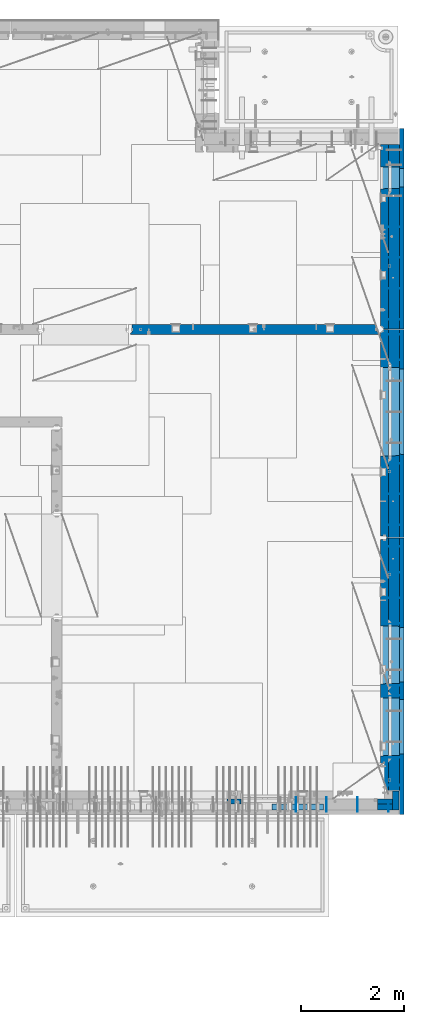
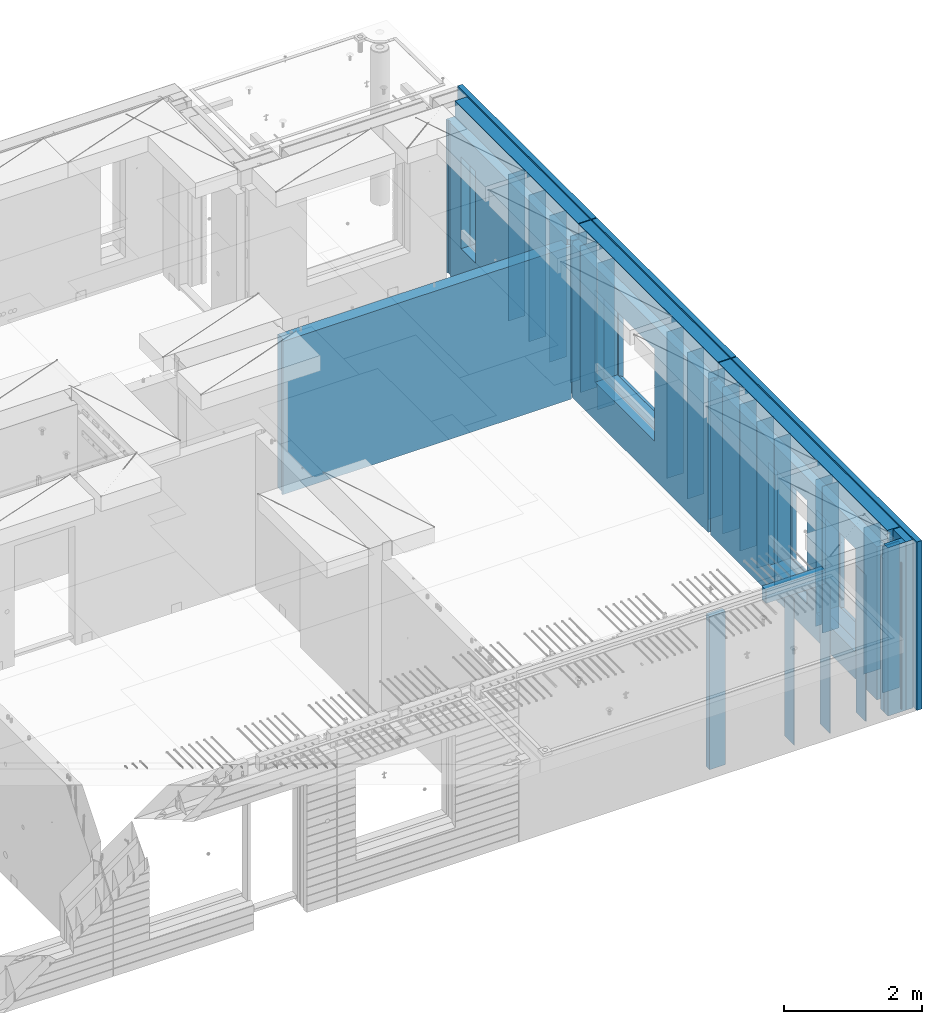
# One storey, part 241 of 349: 37 walls, 7 elements without a shape of their own.
"""IFC2X3 building model written with IfcOpenShell, lengths in millimetres."""

from ifc_helpers import new_model, si_unit, frame, origin_with_axes, place, context, subcontext, project, spatial, faceted_brep, material, type_object, element, aggregate, save


model = new_model("IFC2X3")

# Units and contexts
model_context = context("Model", 3, precision=1e-05, world=origin_with_axes())
body_context = subcontext(model_context, "Body", "Model", "MODEL_VIEW")
ifc_project = project(units=[si_unit("LENGTHUNIT", "METRE", prefix="MILLI"), si_unit("AREAUNIT", "SQUARE_METRE"), si_unit("VOLUMEUNIT", "CUBIC_METRE"), si_unit("MASSUNIT", "GRAM", prefix="KILO"), si_unit("TIMEUNIT", "SECOND"), si_unit("PLANEANGLEUNIT", "RADIAN"), si_unit("SOLIDANGLEUNIT", "STERADIAN"), si_unit("THERMODYNAMICTEMPERATUREUNIT", "DEGREE_CELSIUS"), si_unit("LUMINOUSINTENSITYUNIT", "LUMEN")], contexts=[model_context])

# Site, building, storey
site_placement = place(None, origin_with_axes())
site = spatial("IfcSite", under=ifc_project, at=site_placement, CompositionType="ELEMENT")
building_placement = place(site_placement, origin_with_axes())
building = spatial("IfcBuilding", under=site, at=building_placement, CompositionType="ELEMENT")
storey_placement = place(building_placement, origin_with_axes())
storey = spatial("IfcBuildingStorey", under=building, at=storey_placement, Name="4", CompositionType="ELEMENT", Elevation=0.0)

# Assembly, walls
assembly_1_placement = place(storey_placement, origin_with_axes())
assembly_1 = element("IfcElementAssembly", 1, at=assembly_1_placement, inside=storey, AssemblyPlace="NOTDEFINED", PredefinedType="REINFORCEMENT_UNIT")
ifc_material_1 = material(Name="Undefined")
wall_type_1 = type_object("IfcWallType", PredefinedType="NOTDEFINED")
wall_1_placement = place(assembly_1_placement, frame((35060.0, 7780.0, 92115.0), z_axis=(0.0, 0.0, 1.0), x_axis=(0.0, -1.0, 0.0)))
wall_1 = element("IfcWall", 2, at=wall_1_placement, type_object=wall_type_1, material=ifc_material_1, Name="(PD)", context=body_context, shape_type="Brep", body=[
    faceted_brep([(0.0, 5.0, -1300.0), (0.0, 5.0, 1300.0), (180.0, 5.0, 1300.0), (180.0, 5.0, -1300.0), (0.0, -5.0, 1300.0), (180.0, -5.0, 1300.0), (0.0, -5.0, -1300.0), (180.0, -5.0, -1300.0)], [[[0, 1, 2, 3]], [[1, 4, 5, 2]], [[4, 6, 7, 5]], [[6, 0, 3, 7]], [[5, 7, 3, 2]], [[6, 4, 1, 0]]]),
])
wall_2_placement = place(assembly_1_placement, frame((34460.0, 7880.0, 92115.0), z_axis=(0.0, 0.0, 1.0), x_axis=(0.0, -1.0, 0.0)))
wall_2 = element("IfcWall", 3, at=wall_2_placement, type_object=wall_type_1, material=ifc_material_1, Name="(PD)", context=body_context, shape_type="Brep", body=[
    faceted_brep([(0.0, 5.0, -1300.0), (0.0, 5.0, 1300.0), (280.0, 5.0, 1300.0), (280.0, 5.0, -1300.0), (0.0, -5.0, 1300.0), (280.0, -5.0, 1300.0), (0.0, -5.0, -1300.0), (280.0, -5.0, -1300.0)], [[[0, 1, 2, 3]], [[1, 4, 5, 2]], [[4, 6, 7, 5]], [[6, 0, 3, 7]], [[5, 7, 3, 2]], [[6, 4, 1, 0]]]),
])
wall_3_placement = place(assembly_1_placement, frame((33860.0, 7880.0, 92115.0), z_axis=(0.0, 0.0, 1.0), x_axis=(0.0, -1.0, 0.0)))
wall_3 = element("IfcWall", 4, at=wall_3_placement, type_object=wall_type_1, material=ifc_material_1, Name="(PD)", context=body_context, shape_type="Brep", body=[
    faceted_brep([(0.0, 5.0, -1300.0), (0.0, 5.0, 1300.0), (280.0, 5.0, 1300.0), (280.0, 5.0, -1300.0), (0.0, -5.0, 1300.0), (280.0, -5.0, 1300.0), (0.0, -5.0, -1300.0), (280.0, -5.0, -1300.0)], [[[0, 1, 2, 3]], [[1, 4, 5, 2]], [[4, 6, 7, 5]], [[6, 0, 3, 7]], [[5, 7, 3, 2]], [[6, 4, 1, 0]]]),
])

assembly_2_placement = place(storey_placement, origin_with_axes())
assembly_2 = element("IfcElementAssembly", 5, at=assembly_2_placement, inside=storey, AssemblyPlace="NOTDEFINED", PredefinedType="REINFORCEMENT_UNIT")
wall_4_placement = place(assembly_2_placement, frame((35030.0, 12755.0002861023, 92115.0), z_axis=(0.0, 0.0, 1.0), x_axis=(1.0, 0.0, 0.0)))
wall_4 = element("IfcWall", 6, at=wall_4_placement, type_object=wall_type_1, material=ifc_material_1, Name="(PD)", context=body_context, shape_type="Brep", body=[
    faceted_brep([(0.0, 5.0, -1300.0), (0.0, 5.0, 1300.0), (280.0, 5.0, 1300.0), (280.0, 5.0, -1300.0), (0.0, -5.0, 1300.0), (280.0, -5.0, 1300.0), (0.0, -5.0, -1300.0), (280.0, -5.0, -1300.0)], [[[0, 1, 2, 3]], [[1, 4, 5, 2]], [[4, 6, 7, 5]], [[6, 0, 3, 7]], [[5, 7, 3, 2]], [[6, 4, 1, 0]]]),
])
wall_5_placement = place(assembly_2_placement, frame((35030.0, 12255.0002861023, 92115.0), z_axis=(0.0, 0.0, 1.0), x_axis=(1.0, 0.0, 0.0)))
wall_5 = element("IfcWall", 7, at=wall_5_placement, type_object=wall_type_1, material=ifc_material_1, Name="(PD)", context=body_context, shape_type="Brep", body=[
    faceted_brep([(0.0, 5.0, -1300.0), (0.0, 5.0, 1300.0), (280.0, 5.0, 1300.0), (280.0, 5.0, -1300.0), (0.0, -5.0, 1300.0), (280.0, -5.0, 1300.0), (0.0, -5.0, -1300.0), (280.0, -5.0, -1300.0)], [[[0, 1, 2, 3]], [[1, 4, 5, 2]], [[4, 6, 7, 5]], [[6, 0, 3, 7]], [[5, 7, 3, 2]], [[6, 4, 1, 0]]]),
])
wall_6_placement = place(assembly_2_placement, frame((35030.0, 11755.0002861023, 92115.0), z_axis=(0.0, 0.0, 1.0), x_axis=(1.0, 0.0, 0.0)))
wall_6 = element("IfcWall", 8, at=wall_6_placement, type_object=wall_type_1, material=ifc_material_1, Name="(PD)", context=body_context, shape_type="Brep", body=[
    faceted_brep([(0.0, 5.0, -1300.0), (0.0, 5.0, 1300.0), (280.0, 5.0, 1300.0), (280.0, 5.0, -1300.0), (0.0, -5.0, 1300.0), (280.0, -5.0, 1300.0), (0.0, -5.0, -1300.0), (280.0, -5.0, -1300.0)], [[[0, 1, 2, 3]], [[1, 4, 5, 2]], [[4, 6, 7, 5]], [[6, 0, 3, 7]], [[5, 7, 3, 2]], [[6, 4, 1, 0]]]),
])
wall_7_placement = place(assembly_2_placement, frame((35030.0, 11255.0002861023, 92115.0), z_axis=(0.0, 0.0, 1.0), x_axis=(1.0, 0.0, 0.0)))
wall_7 = element("IfcWall", 9, at=wall_7_placement, type_object=wall_type_1, material=ifc_material_1, Name="(PD)", context=body_context, shape_type="Brep", body=[
    faceted_brep([(0.0, 5.0, -1300.0), (0.0, 5.0, 1300.0), (280.0, 5.0, 1300.0), (280.0, 5.0, -1300.0), (0.0, -5.0, 1300.0), (280.0, -5.0, 1300.0), (0.0, -5.0, -1300.0), (280.0, -5.0, -1300.0)], [[[0, 1, 2, 3]], [[1, 4, 5, 2]], [[4, 6, 7, 5]], [[6, 0, 3, 7]], [[5, 7, 3, 2]], [[6, 4, 1, 0]]]),
])
wall_8_placement = place(assembly_2_placement, frame((35030.0, 8105.0, 92115.0), z_axis=(0.0, 0.0, 1.0), x_axis=(1.0, 0.0, 0.0)))
wall_8 = element("IfcWall", 10, at=wall_8_placement, type_object=wall_type_1, material=ifc_material_1, Name="(PD)", context=body_context, shape_type="Brep", body=[
    faceted_brep([(0.0, 5.0, -1300.0), (0.0, 5.0, 1300.0), (280.0, 5.0, 1300.0), (280.0, 5.0, -1300.0), (0.0, -5.0, 1300.0), (280.0, -5.0, 1300.0), (0.0, -5.0, -1300.0), (280.0, -5.0, -1300.0)], [[[0, 1, 2, 3]], [[1, 4, 5, 2]], [[4, 6, 7, 5]], [[6, 0, 3, 7]], [[5, 7, 3, 2]], [[6, 4, 1, 0]]]),
])
wall_9_placement = place(assembly_2_placement, frame((35030.0, 8115.0, 92115.0), z_axis=(0.0, 0.0, 1.0), x_axis=(1.0, 0.0, 0.0)))
wall_9 = element("IfcWall", 11, at=wall_9_placement, type_object=wall_type_1, material=ifc_material_1, Name="(PD)", context=body_context, shape_type="Brep", body=[
    faceted_brep([(0.0, 5.0, -1300.0), (0.0, 5.0, 1300.0), (280.0, 5.0, 1300.0), (280.0, 5.0, -1300.0), (0.0, -5.0, 1300.0), (280.0, -5.0, 1300.0), (0.0, -5.0, -1300.0), (280.0, -5.0, -1300.0)], [[[0, 1, 2, 3]], [[1, 4, 5, 2]], [[4, 6, 7, 5]], [[6, 0, 3, 7]], [[5, 7, 3, 2]], [[6, 4, 1, 0]]]),
])
wall_10_placement = place(assembly_2_placement, frame((35030.0, 9855.00028610229, 92115.0), z_axis=(0.0, 0.0, 1.0), x_axis=(1.0, 0.0, 0.0)))
wall_10 = element("IfcWall", 12, at=wall_10_placement, type_object=wall_type_1, material=ifc_material_1, Name="(PD)", context=body_context, shape_type="Brep", body=[
    faceted_brep([(0.0, 5.0, -1300.0), (0.0, 5.0, 1300.0), (280.0, 5.0, 1300.0), (280.0, 5.0, -1300.0), (0.0, -5.0, 1300.0), (280.0, -5.0, 1300.0), (0.0, -5.0, -1300.0), (280.0, -5.0, -1300.0)], [[[0, 1, 2, 3]], [[1, 4, 5, 2]], [[4, 6, 7, 5]], [[6, 0, 3, 7]], [[5, 7, 3, 2]], [[6, 4, 1, 0]]]),
])
wall_11_placement = place(assembly_2_placement, frame((35030.0, 10055.0002861023, 92115.0), z_axis=(0.0, 0.0, 1.0), x_axis=(1.0, 0.0, 0.0)))
wall_11 = element("IfcWall", 13, at=wall_11_placement, type_object=wall_type_1, material=ifc_material_1, Name="(PD)", context=body_context, shape_type="Brep", body=[
    faceted_brep([(0.0, 5.0, -1300.0), (0.0, 5.0, 1300.0), (280.0, 5.0, 1300.0), (280.0, 5.0, -1300.0), (0.0, -5.0, 1300.0), (280.0, -5.0, 1300.0), (0.0, -5.0, -1300.0), (280.0, -5.0, -1300.0)], [[[0, 1, 2, 3]], [[1, 4, 5, 2]], [[4, 6, 7, 5]], [[6, 0, 3, 7]], [[5, 7, 3, 2]], [[6, 4, 1, 0]]]),
])

assembly_3_placement = place(storey_placement, origin_with_axes())
assembly_3 = element("IfcElementAssembly", 14, at=assembly_3_placement, inside=storey, AssemblyPlace="NOTDEFINED", PredefinedType="REINFORCEMENT_UNIT")
wall_12_placement = place(assembly_3_placement, frame((35030.0, 13175.0002861023, 92115.0), z_axis=(0.0, 0.0, 1.0), x_axis=(1.0, 0.0, 0.0)))
wall_12 = element("IfcWall", 15, at=wall_12_placement, type_object=wall_type_1, material=ifc_material_1, Name="(PD)", context=body_context, shape_type="Brep", body=[
    faceted_brep([(0.0, 5.0, -1300.0), (0.0, 5.0, 1300.0), (280.0, 5.0, 1300.0), (280.0, 5.0, -1300.0), (0.0, -5.0, 1300.0), (280.0, -5.0, 1300.0), (0.0, -5.0, -1300.0), (280.0, -5.0, -1300.0)], [[[0, 1, 2, 3]], [[1, 4, 5, 2]], [[4, 6, 7, 5]], [[6, 0, 3, 7]], [[5, 7, 3, 2]], [[6, 4, 1, 0]]]),
])
wall_13_placement = place(assembly_3_placement, frame((35030.0, 13775.0002861023, 92115.0), z_axis=(0.0, 0.0, 1.0), x_axis=(1.0, 0.0, 0.0)))
wall_13 = element("IfcWall", 16, at=wall_13_placement, type_object=wall_type_1, material=ifc_material_1, Name="(PD)", context=body_context, shape_type="Brep", body=[
    faceted_brep([(0.0, 5.0, -1300.0), (0.0, 5.0, 1300.0), (280.0, 5.0, 1300.0), (280.0, 5.0, -1300.0), (0.0, -5.0, 1300.0), (280.0, -5.0, 1300.0), (0.0, -5.0, -1300.0), (280.0, -5.0, -1300.0)], [[[0, 1, 2, 3]], [[1, 4, 5, 2]], [[4, 6, 7, 5]], [[6, 0, 3, 7]], [[5, 7, 3, 2]], [[6, 4, 1, 0]]]),
])
wall_14_placement = place(assembly_3_placement, frame((35030.0, 16885.0002861023, 92115.0), z_axis=(0.0, 0.0, 1.0), x_axis=(1.0, 0.0, 0.0)))
wall_14 = element("IfcWall", 17, at=wall_14_placement, type_object=wall_type_1, material=ifc_material_1, Name="(PD)", context=body_context, shape_type="Brep", body=[
    faceted_brep([(0.0, 5.0, -1300.0), (0.0, 5.0, 1300.0), (280.0, 5.0, 1300.0), (280.0, 5.0, -1300.0), (0.0, -5.0, 1300.0), (280.0, -5.0, 1300.0), (0.0, -5.0, -1300.0), (280.0, -5.0, -1300.0)], [[[0, 1, 2, 3]], [[1, 4, 5, 2]], [[4, 6, 7, 5]], [[6, 0, 3, 7]], [[5, 7, 3, 2]], [[6, 4, 1, 0]]]),
])
wall_15_placement = place(assembly_3_placement, frame((35030.0, 16385.0002861023, 92115.0), z_axis=(0.0, 0.0, 1.0), x_axis=(1.0, 0.0, 0.0)))
wall_15 = element("IfcWall", 18, at=wall_15_placement, type_object=wall_type_1, material=ifc_material_1, Name="(PD)", context=body_context, shape_type="Brep", body=[
    faceted_brep([(0.0, 5.0, -1300.0), (0.0, 5.0, 1300.0), (280.0, 5.0, 1300.0), (280.0, 5.0, -1300.0), (0.0, -5.0, 1300.0), (280.0, -5.0, 1300.0), (0.0, -5.0, -1300.0), (280.0, -5.0, -1300.0)], [[[0, 1, 2, 3]], [[1, 4, 5, 2]], [[4, 6, 7, 5]], [[6, 0, 3, 7]], [[5, 7, 3, 2]], [[6, 4, 1, 0]]]),
])

assembly_4_placement = place(storey_placement, origin_with_axes())
assembly_4 = element("IfcElementAssembly", 19, at=assembly_4_placement, inside=storey, AssemblyPlace="NOTDEFINED", PredefinedType="REINFORCEMENT_UNIT")
wall_16_placement = place(assembly_4_placement, frame((35030.0, 17175.0002441406, 92115.0), z_axis=(0.0, 0.0, 1.0), x_axis=(1.0, 0.0, 0.0)))
wall_16 = element("IfcWall", 20, at=wall_16_placement, type_object=wall_type_1, material=ifc_material_1, Name="(PD)", context=body_context, shape_type="Brep", body=[
    faceted_brep([(0.0, 5.0, -1300.0), (0.0, 5.0, 1300.0), (280.0, 5.0, 1300.0), (280.0, 5.0, -1300.0), (0.0, -5.0, 1300.0), (280.0, -5.0, 1300.0), (0.0, -5.0, -1300.0), (280.0, -5.0, -1300.0)], [[[0, 1, 2, 3]], [[1, 4, 5, 2]], [[4, 6, 7, 5]], [[6, 0, 3, 7]], [[5, 7, 3, 2]], [[6, 4, 1, 0]]]),
])
wall_17_placement = place(assembly_4_placement, frame((35030.0, 17775.0002441406, 92115.0), z_axis=(0.0, 0.0, 1.0), x_axis=(1.0, 0.0, 0.0)))
wall_17 = element("IfcWall", 21, at=wall_17_placement, type_object=wall_type_1, material=ifc_material_1, Name="(PD)", context=body_context, shape_type="Brep", body=[
    faceted_brep([(0.0, 5.0, -1300.0), (0.0, 5.0, 1300.0), (280.0, 5.0, 1300.0), (280.0, 5.0, -1300.0), (0.0, -5.0, 1300.0), (280.0, -5.0, 1300.0), (0.0, -5.0, -1300.0), (280.0, -5.0, -1300.0)], [[[0, 1, 2, 3]], [[1, 4, 5, 2]], [[4, 6, 7, 5]], [[6, 0, 3, 7]], [[5, 7, 3, 2]], [[6, 4, 1, 0]]]),
])
wall_18_placement = place(assembly_4_placement, frame((35030.0, 18375.0002441406, 92115.0), z_axis=(0.0, 0.0, 1.0), x_axis=(1.0, 0.0, 0.0)))
wall_18 = element("IfcWall", 22, at=wall_18_placement, type_object=wall_type_1, material=ifc_material_1, Name="(PD)", context=body_context, shape_type="Brep", body=[
    faceted_brep([(0.0, 5.0, -1300.0), (0.0, 5.0, 1300.0), (280.0, 5.0, 1300.0), (280.0, 5.0, -1300.0), (0.0, -5.0, 1300.0), (280.0, -5.0, 1300.0), (0.0, -5.0, -1300.0), (280.0, -5.0, -1300.0)], [[[0, 1, 2, 3]], [[1, 4, 5, 2]], [[4, 6, 7, 5]], [[6, 0, 3, 7]], [[5, 7, 3, 2]], [[6, 4, 1, 0]]]),
])
wall_19_placement = place(assembly_4_placement, frame((35030.0, 18975.0002441406, 92115.0), z_axis=(0.0, 0.0, 1.0), x_axis=(1.0, 0.0, 0.0)))
wall_19 = element("IfcWall", 23, at=wall_19_placement, type_object=wall_type_1, material=ifc_material_1, Name="(PD)", context=body_context, shape_type="Brep", body=[
    faceted_brep([(0.0, 5.0, -1300.0), (0.0, 5.0, 1300.0), (280.0, 5.0, 1300.0), (280.0, 5.0, -1300.0), (0.0, -5.0, 1300.0), (280.0, -5.0, 1300.0), (0.0, -5.0, -1300.0), (280.0, -5.0, -1300.0)], [[[0, 1, 2, 3]], [[1, 4, 5, 2]], [[4, 6, 7, 5]], [[6, 0, 3, 7]], [[5, 7, 3, 2]], [[6, 4, 1, 0]]]),
])

# Wall
wall_20_placement = place(assembly_1_placement, frame((33260.0, 7880.0, 92115.0), z_axis=(0.0, 0.0, 1.0), x_axis=(0.0, -1.0, 0.0)))
wall_20 = element("IfcWall", 24, at=wall_20_placement, type_object=wall_type_1, material=ifc_material_1, Name="(PD)", context=body_context, shape_type="Brep", body=[
    faceted_brep([(0.0, 5.0, -1300.0), (0.0, 5.0, 1300.0), (280.0, 5.0, 1300.0), (280.0, 5.0, -1300.0), (0.0, -5.0, 1300.0), (280.0, -5.0, 1300.0), (0.0, -5.0, -1300.0), (280.0, -5.0, -1300.0)], [[[0, 1, 2, 3]], [[1, 4, 5, 2]], [[4, 6, 7, 5]], [[6, 0, 3, 7]], [[5, 7, 3, 2]], [[6, 4, 1, 0]]]),
])

wall_21_placement = place(assembly_2_placement, frame((35030.0, 8655.0, 92115.0), z_axis=(0.0, 0.0, 1.0), x_axis=(1.0, 0.0, 0.0)))
wall_21 = element("IfcWall", 25, at=wall_21_placement, type_object=wall_type_1, material=ifc_material_1, Name="(PD)", context=body_context, shape_type="Brep", body=[
    faceted_brep([(0.0, 5.0, -1300.0), (0.0, 5.0, 1300.0), (280.0, 5.0, 1300.0), (280.0, 5.0, -1300.0), (0.0, -5.0, 1300.0), (280.0, -5.0, 1300.0), (0.0, -5.0, -1300.0), (280.0, -5.0, -1300.0)], [[[0, 1, 2, 3]], [[1, 4, 5, 2]], [[4, 6, 7, 5]], [[6, 0, 3, 7]], [[5, 7, 3, 2]], [[6, 4, 1, 0]]]),
])

wall_22_placement = place(assembly_3_placement, frame((35030.0, 14375.0002861023, 92115.0), z_axis=(0.0, 0.0, 1.0), x_axis=(1.0, 0.0, 0.0)))
wall_22 = element("IfcWall", 26, at=wall_22_placement, type_object=wall_type_1, material=ifc_material_1, Name="(PD)", context=body_context, shape_type="Brep", body=[
    faceted_brep([(0.0, 5.0, -1300.0), (0.0, 5.0, 1300.0), (280.0, 5.0, 1300.0), (280.0, 5.0, -1300.0), (0.0, -5.0, 1300.0), (280.0, -5.0, 1300.0), (0.0, -5.0, -1300.0), (280.0, -5.0, -1300.0)], [[[0, 1, 2, 3]], [[1, 4, 5, 2]], [[4, 6, 7, 5]], [[6, 0, 3, 7]], [[5, 7, 3, 2]], [[6, 4, 1, 0]]]),
])

# Assembly, wall
assembly_5_placement = place(storey_placement, origin_with_axes())
assembly_5 = element("IfcElementAssembly", 27, at=assembly_5_placement, inside=storey, AssemblyPlace="NOTDEFINED", PredefinedType="REINFORCEMENT_UNIT")
ifc_material_2 = material(Name="CONCRETE/C25/30")
wall_type_2 = type_object("IfcWallType", PredefinedType="NOTDEFINED")
wall_23_placement = place(assembly_5_placement, frame((30040.0, 16980.0002441406, 92112.5), z_axis=(0.0, 0.0, 1.0), x_axis=(1.0, 0.0, 0.0)))
wall_23 = element("IfcWall", 28, at=wall_23_placement, type_object=wall_type_2, material=ifc_material_2, context=body_context, shape_type="Brep", body=[
    faceted_brep([(4785.0, 100.0, 1357.5), (4785.0, -30.0, 1357.5), (4785.0, -30.0, -1357.5), (4785.0, 100.0, -1357.5), (4840.0, -60.0, 1357.5), (4840.0, -60.0, -1357.5), (30.0003214753524, 100.0, 1357.5), (30.0003214753524, 100.0, -1357.5), (30.0003214753524, -57.0, -1357.5), (30.0003214753524, -57.0, 1357.5), (0.0, -70.0001393059865, -1357.5), (0.0, -70.0001393059865, 1357.5), (0.0, -100.0, -1357.5), (0.0, -100.0, 1357.5), (4840.0, -100.0, -1357.5), (4840.0, -100.0, 1357.5)], [[[0, 1, 2, 3]], [[4, 5, 2, 1]], [[6, 7, 8, 9]], [[9, 8, 10, 11]], [[12, 13, 11, 10]], [[13, 12, 14, 15]], [[0, 6, 9, 11, 13, 15, 4, 1]], [[7, 6, 0, 3]], [[14, 12, 10, 8, 7, 3, 2, 5]], [[15, 14, 5, 4]]]),
])
aggregate(assembly_5, [wall_23])

# Assemblies, wall
assembly_6_placement = place(storey_placement, origin_with_axes())
assembly_6 = element("IfcElementAssembly", 29, at=assembly_6_placement, inside=storey, AssemblyPlace="NOTDEFINED", PredefinedType="REINFORCEMENT_UNIT")
assembly_7_placement = place(assembly_6_placement, origin_with_axes())
assembly_7 = element("IfcElementAssembly", 30, at=assembly_7_placement, Name="Steel Assembly", AssemblyPlace="NOTDEFINED", PredefinedType="NOTDEFINED")
aggregate(assembly_6, [assembly_7])
ifc_material_3 = material()
wall_type_3 = type_object("IfcWallType", PredefinedType="NOTDEFINED")
wall_24_placement = place(assembly_7_placement, frame((32799.9998568133, 7690.00021946163, 93590.0), z_axis=(0.0, 0.0, 1.0), x_axis=(1.0, 0.0, 0.0)))
wall_24 = element("IfcWall", 31, at=wall_24_placement, type_object=wall_type_3, material=ifc_material_3, context=body_context, shape_type="Brep", body=[
    faceted_brep([(0.0, 60.0, -120.0), (0.0, 60.0, 120.0), (1000.0, 60.0, 120.0), (1000.0, 60.0, -120.0), (0.0, -60.0, 120.0), (1000.0, -60.0, 120.0), (0.0, -60.0, -120.0), (1000.0, -60.0, -120.0)], [[[0, 1, 2, 3]], [[1, 4, 5, 2]], [[4, 6, 7, 5]], [[6, 0, 3, 7]], [[5, 7, 3, 2]], [[6, 4, 1, 0]]]),
])
aggregate(assembly_7, [wall_24])

# Wall
ifc_material_4 = material(Name="COS5gt")
wall_type_4 = type_object("IfcWallType", PredefinedType="NOTDEFINED")
wall_25_placement = place(assembly_2_placement, frame((35170.0, 12920.0002861023, 92247.5), z_axis=(0.0, 0.0, 1.0), x_axis=(0.0, -1.0, 0.0)))
wall_25 = element("IfcWall", 32, at=wall_25_placement, type_object=wall_type_4, material=ifc_material_4, context=body_context, shape_type="Brep", body=[
    faceted_brep([(0.0, 90.0, 1492.5), (4905.00028610229, 90.0, 1492.5), (4905.00028610229, 90.0, 1442.5), (-0.25, 90.0, 1442.5), (0.0, -110.0, 1492.5), (4905.00028610229, -110.0, 1492.5), (4905.00028610229, 110.0, 1442.5), (4905.00028610229, -110.0, -1492.5), (4905.00028610229, 90.0, -1492.5), (4905.00028610229, 90.0, -1442.5), (4905.00028610229, 110.0, -1442.5), (-0.25, 110.0, 1442.5), (0.0, 90.0, -1492.5), (0.0, -110.0, -1492.5), (-0.25, 110.0, -1442.5), (-0.25, 90.0, -1442.5), (3115.00024333302, 110.0, -1007.5), (3145.00024333302, 110.0, -1007.5), (4195.00024333302, 110.0, -1007.5), (4225.00024333302, 110.0, -1007.5), (4225.00024333302, 110.0, -1002.5), (4225.00024333302, 110.0, 807.5), (3115.00024333302, 110.0, 807.5), (3115.00024333302, 110.0, -1002.5), (1715.00062480275, 110.0, -1007.5), (1745.00062480275, 110.0, -1007.5), (2795.00062480275, 110.0, -1007.5), (2825.00062480275, 110.0, -1007.5), (2825.00062480275, 110.0, -1002.5), (2825.00062480275, 110.0, 807.5), (1715.00062480275, 110.0, 807.5), (1715.00062480275, 110.0, -1002.5), (4230.94618927897, -110.0, -1013.44594594595), (4230.94618927897, -110.0, 813.445945945947), (3109.05429738708, -110.0, -1013.44594594595), (3109.05429738708, -110.0, 813.445945945947), (2830.9465707487, -110.0, -1013.44594594595), (1709.0546788568, -110.0, -1013.44594594595), (1709.0546788568, -110.0, 813.445945945947), (2830.9465707487, -110.0, 813.445945945947)], [[[0, 1, 2, 3]], [[4, 5, 1, 0]], [[6, 2, 1, 5, 7, 8, 9, 10]], [[11, 3, 2, 6]], [[12, 13, 4, 0, 3, 11, 14, 15]], [[7, 13, 12, 8]], [[15, 9, 8, 12]], [[14, 10, 9, 15]], [[11, 6, 10, 14], [16, 17, 18, 19, 20, 21, 22, 23], [24, 25, 26, 27, 28, 29, 30, 31]], [[20, 19, 32, 33, 21]], [[18, 17, 16, 34, 32, 19]], [[23, 22, 35, 34, 16]], [[21, 33, 35, 22]], [[4, 13, 7, 5], [32, 34, 35, 33], [36, 37, 38, 39]], [[26, 25, 24, 37, 36, 27]], [[31, 30, 38, 37, 24]], [[29, 39, 38, 30]], [[28, 27, 36, 39, 29]]]),
])

wall_26_placement = place(assembly_3_placement, frame((35170.0, 16980.0002861023, 92247.5), z_axis=(0.0, 0.0, 1.0), x_axis=(0.0, -1.0, 0.0)))
wall_26 = element("IfcWall", 33, at=wall_26_placement, type_object=wall_type_4, material=ifc_material_4, context=body_context, shape_type="Brep", body=[
    faceted_brep([(1409.0, 90.0, -1492.5), (1409.0, 90.0, -1442.5), (4045.0, 90.0, -1442.5), (4045.0, 90.0, -1492.5), (5.0, 110.0, -1492.5), (5.0, -110.0, -1492.5), (5.0, -110.0, 1492.5), (5.00004196166992, 90.0, 1492.5), (5.00004196166992, 90.0, 1442.5), (5.00004196166992, 110.0, 1442.5), (4045.0, -110.0, -1492.5), (4045.0, -110.0, 1492.5), (2460.94588410319, -110.0, -813.445945945947), (739.053992211293, -110.0, -813.445945945947), (739.053992211293, -110.0, 813.445945945947), (2460.94588410319, -110.0, 813.445945945947), (2454.99993815724, 110.0, 807.5), (744.99993815724, 110.0, 807.5), (2454.99993815724, 110.0, -802.5), (2454.99993815724, 110.0, -807.5), (2424.99993815724, 110.0, -807.5), (774.99993815724, 110.0, -807.5), (744.99993815724, 110.0, -807.5), (744.99993815724, 110.0, -802.5), (4045.0, 110.0, 1442.5), (4045.0, 110.0, -1442.5), (1409.0, 110.0, -1442.5), (1409.0, 110.0, -1492.5), (4045.0, 90.0, 1442.5), (4045.0, 90.0, 1492.5)], [[[0, 1, 2, 3]], [[4, 5, 6, 7, 8, 9]], [[6, 5, 10, 11], [12, 13, 14, 15]], [[16, 15, 14, 17]], [[18, 19, 12, 15, 16]], [[20, 21, 22, 13, 12, 19]], [[23, 17, 14, 13, 22]], [[4, 9, 24, 25, 26, 27], [22, 21, 20, 19, 18, 16, 17, 23]], [[3, 10, 5, 4, 27, 0]], [[26, 1, 0, 27]], [[25, 2, 1, 26]], [[24, 28, 29, 11, 10, 3, 2, 25]], [[9, 8, 28, 24]], [[7, 29, 28, 8]], [[6, 11, 29, 7]]]),
])

wall_27_placement = place(assembly_4_placement, frame((35170.0, 20575.0002441406, 92247.5), z_axis=(0.0, 0.0, 1.0), x_axis=(0.0, -1.0, 0.0)))
wall_27 = element("IfcWall", 34, at=wall_27_placement, type_object=wall_type_4, material=ifc_material_4, context=body_context, shape_type="Brep", body=[
    faceted_brep([(0.0, 90.0, 1492.5), (3585.0, 90.0, 1492.5), (3585.0, 90.0, 1442.5), (0.0, 90.0, 1442.5), (0.0, -110.0, 1492.5), (3585.0, -110.0, 1492.5), (3585.0, 110.0, 1442.5), (3585.0, -110.0, -1492.5), (3585.0, 90.0, -1492.5), (3585.0, 90.0, -1442.5), (3585.0, 110.0, -1442.5), (0.0, 110.0, 1442.5), (0.0, 90.0, -1492.5), (0.0, -110.0, -1492.5), (0.0, 110.0, -1442.5), (0.0, 90.0, -1442.5), (440.000277665298, 110.0, -807.5), (470.000277665298, 110.0, -807.5), (820.000277665298, 110.0, -807.5), (850.000277665298, 110.0, -807.5), (850.000277665298, 110.0, -802.5), (850.000277665298, 110.0, 807.5), (440.000277665298, 110.0, 807.5), (440.000277665298, 110.0, -802.5), (855.946223611245, -110.0, -813.445945945947), (855.946223611245, -110.0, 813.445945945947), (434.054331719351, -110.0, -813.445945945947), (434.054331719351, -110.0, 813.445945945947)], [[[0, 1, 2, 3]], [[4, 5, 1, 0]], [[6, 2, 1, 5, 7, 8, 9, 10]], [[11, 3, 2, 6]], [[12, 13, 4, 0, 3, 11, 14, 15]], [[7, 13, 12, 8]], [[15, 9, 8, 12]], [[14, 10, 9, 15]], [[11, 6, 10, 14], [16, 17, 18, 19, 20, 21, 22, 23]], [[20, 19, 24, 25, 21]], [[18, 17, 16, 26, 24, 19]], [[23, 22, 27, 26, 16]], [[21, 25, 27, 22]], [[4, 13, 7, 5], [24, 26, 27, 25]]]),
])

ifc_material_5 = material(Name="CONCRETE/C30/37")
wall_type_5 = type_object("IfcWallType", PredefinedType="NOTDEFINED")
wall_28_placement = place(assembly_2_placement, frame((35322.5, 12920.2502861023, 92247.5), z_axis=(0.0, 0.0, 1.0), x_axis=(0.0, -1.0, 0.0)))
wall_28 = element("IfcWall", 35, at=wall_28_placement, type_object=wall_type_5, material=ifc_material_5, context=body_context, shape_type="Brep", body=[
    faceted_brep([(0.0, 42.5, 1492.5), (0.0, -42.5, 1492.5), (5375.25028610229, -42.5, 1492.5), (5375.25028610229, 42.5, 1492.5), (0.0, -42.5, -1492.5), (0.0, 42.5, -1492.5), (5375.25028610229, 42.5, -1492.5), (5375.25028610229, -42.5, -1492.5), (4205.25024333302, 42.5, -1057.5), (4195.25024333302, -42.5, -1007.5), (4195.25024333302, -42.5, 782.5), (4195.25024333302, -42.5, 787.5), (4205.25024333302, 42.5, 782.5), (3135.25024333302, 42.5, -1057.5), (3145.25024333302, -42.5, -1007.5), (3135.25024333302, 42.5, 782.5), (3145.25024333302, -42.5, 787.5), (3145.25024333302, -42.5, 782.5), (3145.25024333302, 42.5, 782.5), (4195.25024333302, 42.5, 782.5), (2795.25062480275, -42.5, 782.5), (2795.25062480275, -42.5, -1007.5), (1745.25062480275, -42.5, -1007.5), (1745.25062480275, -42.5, 782.5), (1745.25062480275, -42.5, 787.5), (2795.25062480275, -42.5, 787.5), (1745.25062480275, 42.5, 782.5), (2795.25062480275, 42.5, 782.5), (2805.25062480275, 42.5, 782.5), (1735.25062480275, 42.5, 782.5), (2805.25062480275, 42.5, -1057.5), (1735.25062480275, 42.5, -1057.5)], [[[0, 1, 2, 3]], [[4, 5, 6, 7]], [[2, 7, 6, 3]], [[8, 9, 10, 11, 12]], [[13, 14, 9, 8]], [[15, 16, 17, 14, 13]], [[18, 19, 12, 11, 16, 15]], [[1, 4, 7, 2], [20, 21, 22, 23, 24, 25], [10, 9, 14, 17, 16, 11]], [[26, 27, 28, 25, 24, 29]], [[30, 21, 20, 25, 28]], [[31, 22, 21, 30]], [[29, 24, 23, 22, 31]], [[5, 0, 3, 6], [30, 28, 27, 26, 29, 31], [8, 12, 19, 18, 15, 13]], [[4, 1, 0, 5]]]),
])

wall_29_placement = place(assembly_3_placement, frame((35322.5, 16980.0002861023, 92247.5), z_axis=(0.0, 0.0, 1.0), x_axis=(0.0, -1.0, 0.0)))
wall_29 = element("IfcWall", 36, at=wall_29_placement, type_object=wall_type_5, material=ifc_material_5, context=body_context, shape_type="Brep", body=[
    faceted_brep([(5.00004196166992, 42.5, 1492.5), (5.00004196166992, -42.5, 1492.5), (4045.0, -42.5, 1492.5), (4045.0, 42.5, 1492.5), (5.00004196166992, -42.5, -1492.5), (5.00004196166992, 42.5, -1492.5), (4045.0, 42.5, -1492.5), (4045.0, -42.5, -1492.5), (2424.99993815724, -42.5, 782.5), (2424.99993815724, -42.5, 781.785034179688), (2424.99993815724, -42.5, -807.5), (774.99993815724, -42.5, -807.5), (774.99993815724, -42.5, 781.785034179688), (774.99993815724, -42.5, 782.5), (774.99993815724, -42.5, 787.5), (2424.99993815724, -42.5, 787.5), (774.99993815724, 42.5, 782.5), (2424.99993815724, 42.5, 782.5), (2434.99993815724, 42.5, 782.5), (764.99993815724, 42.5, 782.5), (2434.99993815724, 42.5, -857.5), (764.99993815724, 42.5, -857.5)], [[[0, 1, 2, 3]], [[4, 5, 6, 7]], [[2, 7, 6, 3]], [[1, 4, 7, 2], [8, 9, 10, 11, 12, 13, 14, 15]], [[16, 17, 18, 15, 14, 19]], [[20, 10, 9, 8, 15, 18]], [[21, 11, 10, 20]], [[19, 14, 13, 12, 11, 21]], [[5, 0, 3, 6], [20, 18, 17, 16, 19, 21]], [[4, 1, 0, 5]]]),
])

wall_30_placement = place(assembly_4_placement, frame((35322.5, 20432.0002441406, 92247.5), z_axis=(0.0, 0.0, 1.0), x_axis=(0.0, -1.0, 0.0)))
wall_30 = element("IfcWall", 37, at=wall_30_placement, type_object=wall_type_5, material=ifc_material_5, context=body_context, shape_type="Brep", body=[
    faceted_brep([(-453.0, -42.5, -1492.5), (-453.0, -42.5, 1492.5), (-453.0, 42.5, 1492.5), (-453.0, 42.5, -1492.5), (3442.0, 42.5, -1492.5), (3442.0, -42.5, -1492.5), (3442.0, -42.5, 1492.5), (677.000277665298, -42.5, 782.5), (677.000277665298, -42.5, -807.5), (327.000277665298, -42.5, -807.5), (327.000277665298, -42.5, 782.5), (327.000277665298, -42.5, 787.5), (677.000277665298, -42.5, 787.5), (327.000277665298, 42.5, 782.5), (677.000277665298, 42.5, 782.5), (687.000277665298, 42.5, 782.5), (317.000277665298, 42.5, 782.5), (687.000277665298, 42.5, -857.5), (317.000277665298, 42.5, -857.5), (3442.0, 42.5, 1492.5)], [[[0, 1, 2, 3]], [[0, 3, 4, 5]], [[1, 0, 5, 6], [7, 8, 9, 10, 11, 12]], [[13, 14, 15, 12, 11, 16]], [[17, 8, 7, 12, 15]], [[18, 9, 8, 17]], [[16, 11, 10, 9, 18]], [[3, 2, 19, 4], [17, 15, 14, 13, 16, 18]], [[6, 5, 4, 19]], [[2, 1, 6, 19]]]),
])

wall_type_6 = type_object("IfcWallType", PredefinedType="NOTDEFINED")
wall_31_placement = place(assembly_2_placement, frame((34985.0, 12920.0002861023, 92112.5), z_axis=(0.0, 0.0, 1.0), x_axis=(0.0, -1.0, 0.0)))
wall_31 = element("IfcWall", 38, at=wall_31_placement, type_object=wall_type_6, material=ifc_material_2, context=body_context, shape_type="Brep", body=[
    faceted_brep([(4855.00028610229, -75.0, 1357.5), (4855.00028610229, -75.0, -1357.5), (4855.00028610229, 32.0000069488524, -1357.5), (4855.00028610229, 32.0000069488524, 1357.5), (4905.00028610229, 45.0000069488524, 1357.5), (4905.00028610229, 45.0000069488524, -1357.5), (29.9999989126591, 32.0000004547946, 1357.5), (29.9999989126591, 32.0000004547946, -1357.5), (30.0000016637459, -75.0, -1357.5), (30.0000016637459, -75.0, 1357.5), (0.0, 45.0, 1357.5), (0.0, 45.0, -1357.5), (0.0, 75.0, 1357.5), (0.0, 75.0, -1357.5), (4905.00028610229, 75.0, -1357.5), (4905.00028610229, 75.0, 1357.5), (4230.94618927897, 75.0, 948.445945945947), (4235.00024333302, -75.0, 952.5), (3105.00024333302, -75.0, 952.5), (3109.05429738708, 75.0, 948.445945945947), (4230.94618927897, 75.0, -878.445945945947), (4235.00024333302, -75.0, -882.5), (3109.05429738708, 75.0, -878.445945945947), (3105.00024333302, -75.0, -882.5), (2830.9465707487, 75.0, -878.445945945947), (2830.9465707487, 75.0, 948.445945945947), (1709.0546788568, 75.0, 948.445945945947), (1709.0546788568, 75.0, -878.445945945947), (2835.00062480275, -75.0, -882.5), (2835.00062480275, -75.0, 952.5), (1705.00062480275, -75.0, -882.5), (1705.00062480275, -75.0, 952.5)], [[[0, 1, 2, 3]], [[4, 3, 2, 5]], [[6, 7, 8, 9]], [[10, 11, 7, 6]], [[12, 13, 11, 10]], [[1, 8, 7, 11, 13, 14, 5, 2]], [[14, 15, 4, 5]], [[16, 17, 18, 19]], [[20, 21, 17, 16]], [[22, 23, 21, 20]], [[19, 18, 23, 22]], [[13, 12, 15, 14], [20, 16, 19, 22], [24, 25, 26, 27]], [[24, 28, 29, 25]], [[27, 30, 28, 24]], [[26, 31, 30, 27]], [[25, 29, 31, 26]], [[9, 8, 1, 0], [28, 30, 31, 29], [21, 23, 18, 17]], [[15, 12, 10, 6, 9, 0, 3, 4]]]),
])

aggregate(assembly_2, [wall_4, wall_5, wall_6, wall_7, wall_8, wall_9, wall_10, wall_11, wall_21, wall_28, wall_25, wall_31])

wall_32_placement = place(assembly_3_placement, frame((34985.0, 16980.0002861023, 92112.5), z_axis=(0.0, 0.0, 1.0), x_axis=(0.0, -1.0, 0.0)))
wall_32 = element("IfcWall", 39, at=wall_32_placement, type_object=wall_type_6, material=ifc_material_2, context=body_context, shape_type="Brep", body=[
    faceted_brep([(5.0, 75.0, -1357.5), (5.0, 75.0, 1357.5), (4045.0, 75.0, 1357.5), (4045.0, 75.0, -1357.5), (2460.94588410319, 75.0, -678.445945945947), (2460.94588410319, 75.0, 948.445945945947), (739.053992211293, 75.0, 948.445945945947), (739.053992211293, 75.0, -678.445945945947), (5.0, -15.0000022791291, -1357.5), (5.0, -15.0000022791291, 1357.5), (65.0, -75.0, 1357.5), (65.0, -75.0, -1357.5), (4015.0, -75.0, 1357.5), (4015.0, 32.0, 1357.5), (4045.0, 45.0, 1357.5), (4045.0, 45.0, -1357.5), (4015.0, -75.0, -1357.5), (4015.0, 32.0, -1357.5), (2464.99993815724, -75.0, -682.5), (734.99993815724, -75.0, -682.5), (734.99993815724, -75.0, 952.5), (2464.99993815724, -75.0, 952.5)], [[[0, 1, 2, 3], [4, 5, 6, 7]], [[1, 0, 8, 9]], [[10, 9, 8, 11]], [[2, 1, 9, 10, 12, 13, 14]], [[3, 2, 14, 15]], [[16, 11, 8, 0, 3, 15, 17]], [[14, 13, 17, 15]], [[12, 16, 17, 13]], [[10, 11, 16, 12], [18, 19, 20, 21]], [[6, 20, 19, 7]], [[5, 21, 20, 6]], [[4, 18, 21, 5]], [[7, 19, 18, 4]]]),
])

aggregate(assembly_3, [wall_12, wall_13, wall_14, wall_15, wall_22, wall_26, wall_29, wall_32])

wall_33_placement = place(assembly_4_placement, frame((34985.0, 20575.0002441406, 92112.5), z_axis=(0.0, 0.0, 1.0), x_axis=(0.0, -1.0, 0.0)))
wall_33 = element("IfcWall", 40, at=wall_33_placement, type_object=wall_type_6, material=ifc_material_2, context=body_context, shape_type="Brep", body=[
    faceted_brep([(0.0, 75.0, -1357.5), (0.0, 75.0, 1357.5), (3585.0, 75.0, 1357.5), (3585.0, 75.0, -1357.5), (855.946223611245, 75.0, -678.445945945947), (855.946223611245, 75.0, 948.445945945947), (434.054331719351, 75.0, 948.445945945947), (434.054331719351, 75.0, -678.445945945947), (0.0, -75.0, -1357.5), (0.0, -75.0, 1357.5), (30.0050569130617, -75.0, -1357.5), (30.0050569130617, -75.0, 1357.5), (43.0050569130617, -55.0, -1357.5), (43.0050569130617, -55.0, 1357.5), (97.0050569130617, -55.0, -1357.5), (97.0050569130617, -55.0, 1357.5), (110.005056913062, -75.0, -1357.5), (110.005056913062, -75.0, 1357.5), (3525.0, -75.0, 1357.5), (3585.0, -15.0, 1357.5), (3585.0, -15.0, -1357.5), (3525.0, -75.0, -1357.5), (860.000277665298, -75.0, -682.5), (430.000277665298, -75.0, -682.5), (430.000277665298, -75.0, 952.5), (860.000277665298, -75.0, 952.5)], [[[0, 1, 2, 3], [4, 5, 6, 7]], [[8, 9, 1, 0]], [[9, 8, 10, 11]], [[11, 10, 12, 13]], [[13, 12, 14, 15]], [[15, 14, 16, 17]], [[2, 1, 9, 11, 13, 15, 17, 18, 19]], [[3, 2, 19, 20]], [[16, 14, 12, 10, 8, 0, 3, 20, 21]], [[19, 18, 21, 20]], [[17, 16, 21, 18], [22, 23, 24, 25]], [[6, 24, 23, 7]], [[5, 25, 24, 6]], [[4, 22, 25, 5]], [[7, 23, 22, 4]]]),
])

aggregate(assembly_4, [wall_16, wall_17, wall_18, wall_19, wall_30, wall_27, wall_33])

ifc_material_6 = material(Name="CONCRETE/C35/45")
wall_type_7 = type_object("IfcWallType", PredefinedType="NOTDEFINED")
wall_34_placement = place(assembly_1_placement, frame((35145.0000381475, 7800.0, 92112.5), z_axis=(0.0, 0.0, 1.0), x_axis=(-1.0, 3.00000001838171e-08, 0.0)))
wall_34 = element("IfcWall", 41, at=wall_34_placement, type_object=wall_type_7, material=ifc_material_6, context=body_context, shape_type="Brep", body=[
    faceted_brep([(0.0, 50.0, -1357.5), (0.0, 50.0, 1357.5), (300.001908754726, 50.0, 1357.5), (300.001908754726, 50.0, -1357.5), (0.0, -50.0, 1357.5), (300.001908754726, -50.0, 1357.5), (0.0, -50.0, -1357.5), (300.001908754726, -50.0, -1357.5)], [[[0, 1, 2, 3]], [[1, 4, 5, 2]], [[4, 6, 7, 5]], [[6, 0, 3, 7]], [[5, 7, 3, 2]], [[6, 4, 1, 0]]]),
])

wall_35_placement = place(assembly_1_placement, frame((32195.0000381475, 7800.0, 92112.5), z_axis=(0.0, 0.0, 1.0), x_axis=(-1.0, 3.00000001838171e-08, 0.0)))
wall_35 = element("IfcWall", 42, at=wall_35_placement, type_object=wall_type_7, material=ifc_material_6, context=body_context, shape_type="Brep", body=[
    faceted_brep([(0.0, 50.0, -1357.5), (0.0, 50.0, 1357.5), (270.001908754726, 50.0, 1357.5), (270.001908754726, 50.0, -1357.5), (0.0, -50.0, 1357.5), (270.001908754726, -50.0, 1357.5), (0.0, -50.0, -1357.5), (270.001908754726, -50.0, -1357.5)], [[[0, 1, 2, 3]], [[1, 4, 5, 2]], [[4, 6, 7, 5]], [[6, 0, 3, 7]], [[5, 7, 3, 2]], [[6, 4, 1, 0]]]),
])

ifc_material_7 = material(Name="SPU")
wall_type_8 = type_object("IfcWallType", PredefinedType="NOTDEFINED")
wall_36_placement = place(assembly_1_placement, frame((35145.0000381475, 7690.0, 92247.5), z_axis=(0.0, 0.0, 1.0), x_axis=(-1.0, 3.00000001838171e-08, 0.0)))
wall_36 = element("IfcWall", 43, at=wall_36_placement, type_object=wall_type_8, material=ifc_material_7, context=body_context, shape_type="Brep", body=[
    faceted_brep([(0.0, 60.0, -1492.5), (0.0, 60.0, 1492.5), (300.001908754726, 60.0, 1492.5), (300.001908754726, 60.0, -1492.5), (0.0, -60.0, 1492.5), (300.001908754726, -60.0, 1492.5), (0.0, -60.0, -1492.5), (300.001908754726, -60.0, -1492.5)], [[[0, 1, 2, 3]], [[1, 4, 5, 2]], [[4, 6, 7, 5]], [[6, 0, 3, 7]], [[5, 7, 3, 2]], [[6, 4, 1, 0]]]),
])

wall_37_placement = place(assembly_1_placement, frame((35205.0, 8000.0, 92247.5), z_axis=(0.0, 0.0, 1.0), x_axis=(0.0, -1.0, 0.0)))
wall_37 = element("IfcWall", 44, at=wall_37_placement, type_object=wall_type_8, material=ifc_material_7, context=body_context, shape_type="Brep", body=[
    faceted_brep([(0.0, 60.0, -1492.5), (0.0, 60.0, 1492.5), (370.0, 60.0, 1492.5), (370.0, 60.0, -1492.5), (0.0, -60.0, 1492.5), (370.0, -60.0, 1492.5), (0.0, -60.0, -1492.5), (370.0, -60.0, -1492.5)], [[[0, 1, 2, 3]], [[1, 4, 5, 2]], [[4, 6, 7, 5]], [[6, 0, 3, 7]], [[5, 7, 3, 2]], [[6, 4, 1, 0]]]),
])

aggregate(assembly_1, [wall_36, wall_34, wall_1, wall_2, wall_3, wall_37, wall_20, wall_35])

save(model, "model.ifc")
